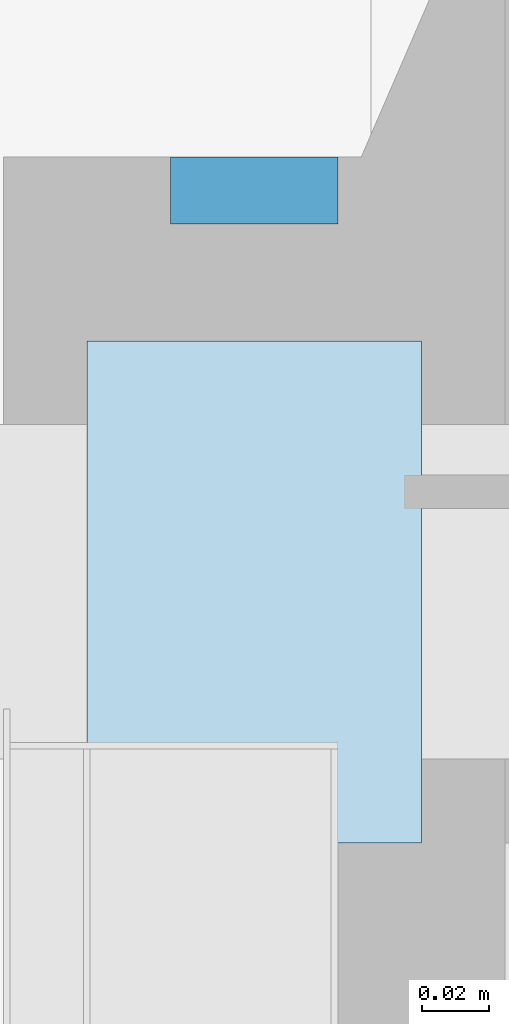
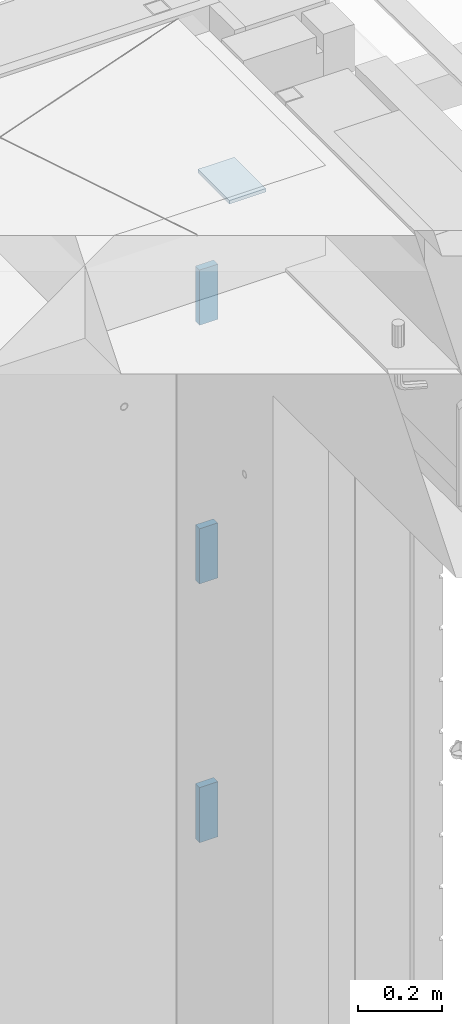
# One storey, part 215 of 341: 4 plates, 5 elements without a shape of their own.
"""IFC2X3 building model written with IfcOpenShell, lengths in millimetres."""

from ifc_helpers import new_model, si_unit, frame, origin_with_axes, place, context, subcontext, project, spatial, faceted_brep, material, type_object, element, aggregate, save


model = new_model("IFC2X3")

# Units and contexts
model_context = context("Model", 3, precision=1e-05, world=origin_with_axes())
body_context = subcontext(model_context, "Body", "Model", "MODEL_VIEW")
ifc_project = project(units=[si_unit("LENGTHUNIT", "METRE", prefix="MILLI"), si_unit("AREAUNIT", "SQUARE_METRE"), si_unit("VOLUMEUNIT", "CUBIC_METRE"), si_unit("MASSUNIT", "GRAM", prefix="KILO"), si_unit("TIMEUNIT", "SECOND"), si_unit("PLANEANGLEUNIT", "RADIAN"), si_unit("SOLIDANGLEUNIT", "STERADIAN"), si_unit("THERMODYNAMICTEMPERATUREUNIT", "DEGREE_CELSIUS"), si_unit("LUMINOUSINTENSITYUNIT", "LUMEN")], contexts=[model_context])

# Site, building, storey
site_placement = place(None, origin_with_axes())
site = spatial("IfcSite", under=ifc_project, at=site_placement, CompositionType="ELEMENT")
building_placement = place(site_placement, origin_with_axes())
building = spatial("IfcBuilding", under=site, at=building_placement, CompositionType="ELEMENT")
storey_placement = place(building_placement, origin_with_axes())
storey = spatial("IfcBuildingStorey", under=building, at=storey_placement, Name="5", CompositionType="ELEMENT", Elevation=0.0)

# Assemblies, plates
assembly_1_placement = place(storey_placement, origin_with_axes())
assembly_1 = element("IfcElementAssembly", 1, at=assembly_1_placement, inside=storey, AssemblyPlace="NOTDEFINED", PredefinedType="REINFORCEMENT_UNIT")
assembly_2_placement = place(assembly_1_placement, origin_with_axes())
assembly_2 = element("IfcElementAssembly", 2, at=assembly_2_placement, Name="Steel Assembly", AssemblyPlace="NOTDEFINED", PredefinedType="RIGID_FRAME")
ifc_material = material(Name="STEEL/Steel_Undefined")
plate_type_1 = type_object("IfcPlateType", PredefinedType="NOTDEFINED")
plate_1_placement = place(assembly_2_placement, frame((31409.9951872276, 22535.0, 96067.5), z_axis=(0.0, 1.0, 0.0), x_axis=(-1.0, 3.00000001838171e-08, 0.0)))
plate_1 = element("IfcPlate", 3, at=plate_1_placement, type_object=plate_type_1, material=ifc_material, Name="VL_080", context=body_context, shape_type="Brep", body=[
    faceted_brep([(0.0, -80.0, 0.0), (0.0, -80.0, 20.0), (0.0, 80.0, 20.0), (0.0, 80.0, 0.0), (50.0, -80.0, 20.0), (50.0, 80.0, 20.0), (50.0, -80.0, 0.0), (50.0, 80.0, 0.0)], [[[0, 1, 2, 3]], [[1, 4, 5, 2]], [[4, 6, 7, 5]], [[6, 0, 3, 7]], [[5, 7, 3, 2]], [[6, 4, 1, 0]]]),
])
aggregate(assembly_2, [plate_1])
assembly_3_placement = place(assembly_1_placement, origin_with_axes())
assembly_3 = element("IfcElementAssembly", 4, at=assembly_3_placement, Name="Steel Assembly", AssemblyPlace="NOTDEFINED", PredefinedType="RIGID_FRAME")
plate_2_placement = place(assembly_3_placement, frame((31409.9951872276, 22535.0, 95317.5), z_axis=(0.0, 1.0, 0.0), x_axis=(-1.0, 3.00000001838171e-08, 0.0)))
plate_2 = element("IfcPlate", 5, at=plate_2_placement, type_object=plate_type_1, material=ifc_material, Name="VL_080", context=body_context, shape_type="Brep", body=[
    faceted_brep([(0.0, -80.0, 0.0), (0.0, -80.0, 20.0), (0.0, 80.0, 20.0), (0.0, 80.0, 0.0), (50.0, -80.0, 20.0), (50.0, 80.0, 20.0), (50.0, -80.0, 0.0), (50.0, 80.0, 0.0)], [[[0, 1, 2, 3]], [[1, 4, 5, 2]], [[4, 6, 7, 5]], [[6, 0, 3, 7]], [[5, 7, 3, 2]], [[6, 4, 1, 0]]]),
])
aggregate(assembly_3, [plate_2])
assembly_4_placement = place(assembly_1_placement, origin_with_axes())
assembly_4 = element("IfcElementAssembly", 6, at=assembly_4_placement, Name="Steel Assembly", AssemblyPlace="NOTDEFINED", PredefinedType="RIGID_FRAME")
plate_3_placement = place(assembly_4_placement, frame((31409.9951872276, 22535.0, 94567.5), z_axis=(0.0, 1.0, 0.0), x_axis=(-1.0, 3.00000001838171e-08, 0.0)))
plate_3 = element("IfcPlate", 7, at=plate_3_placement, type_object=plate_type_1, material=ifc_material, Name="VL_080", context=body_context, shape_type="Brep", body=[
    faceted_brep([(0.0, -80.0, 0.0), (0.0, -80.0, 20.0), (0.0, 80.0, 20.0), (0.0, 80.0, 0.0), (50.0, -80.0, 20.0), (50.0, 80.0, 20.0), (50.0, -80.0, 0.0), (50.0, 80.0, 0.0)], [[[0, 1, 2, 3]], [[1, 4, 5, 2]], [[4, 6, 7, 5]], [[6, 0, 3, 7]], [[5, 7, 3, 2]], [[6, 4, 1, 0]]]),
])
aggregate(assembly_4, [plate_3])
assembly_5_placement = place(assembly_1_placement, origin_with_axes())
assembly_5 = element("IfcElementAssembly", 8, at=assembly_5_placement, Name="Steel Assembly", AssemblyPlace="NOTDEFINED", PredefinedType="RIGID_FRAME")
aggregate(assembly_1, [assembly_2, assembly_3, assembly_4, assembly_5])
plate_type_2 = type_object("IfcPlateType", PredefinedType="NOTDEFINED")
plate_4_placement = place(assembly_5_placement, frame((31334.9951872276, 22350.0, 96465.0), z_axis=(0.0, 1.0, 0.0), x_axis=(1.0, 0.0, 0.0)))
plate_4 = element("IfcPlate", 9, at=plate_4_placement, type_object=plate_type_2, material=ifc_material, Name="KL100x150", context=body_context, shape_type="Brep", body=[
    faceted_brep([(0.0, -5.0, 0.0), (7.27595761418343e-11, -5.0, 150.0), (7.27595761418343e-11, 5.0, 150.0), (0.0, 5.0, 0.0), (100.0, -5.0, 150.0), (100.0, 5.0, 150.0), (100.0, -5.0, 0.0), (100.0, 5.0, 0.0)], [[[0, 1, 2, 3]], [[1, 4, 5, 2]], [[4, 6, 7, 5]], [[6, 0, 3, 7]], [[5, 7, 3, 2]], [[6, 4, 1, 0]]]),
])
aggregate(assembly_5, [plate_4])

save(model, "model.ifc")
